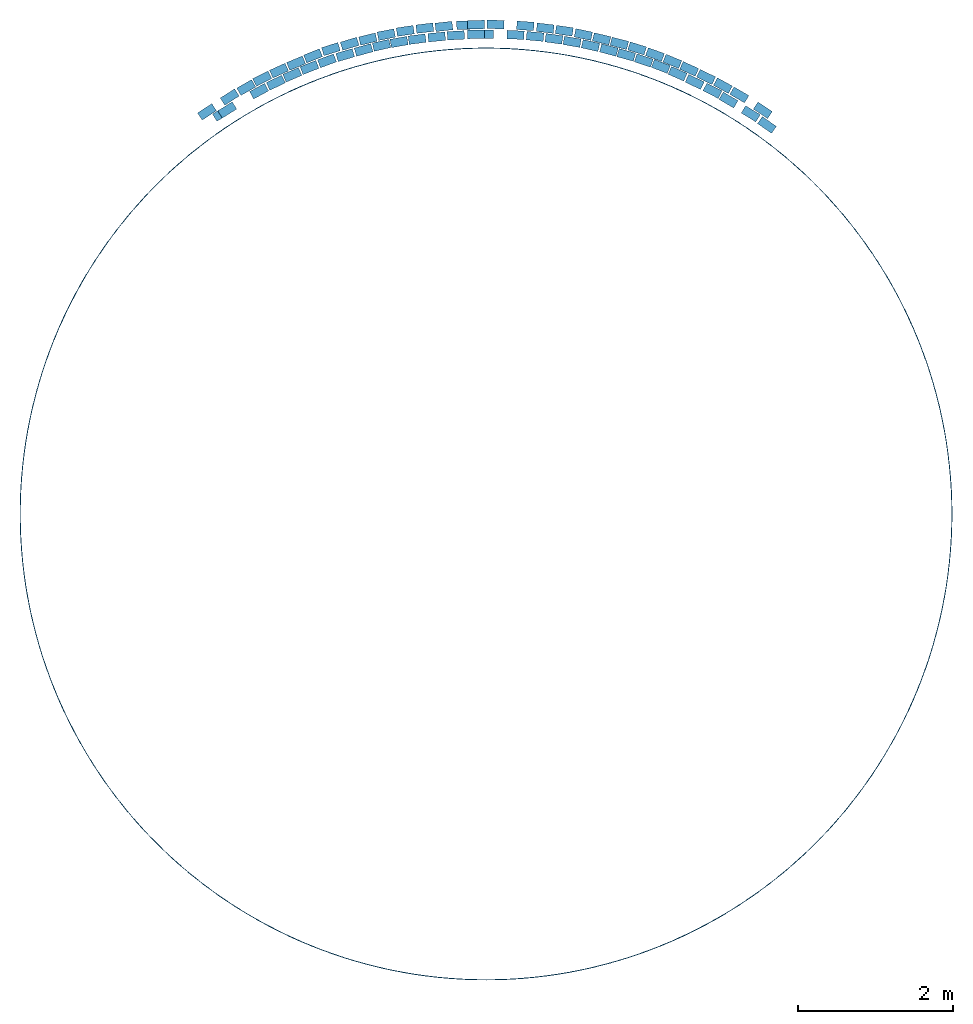
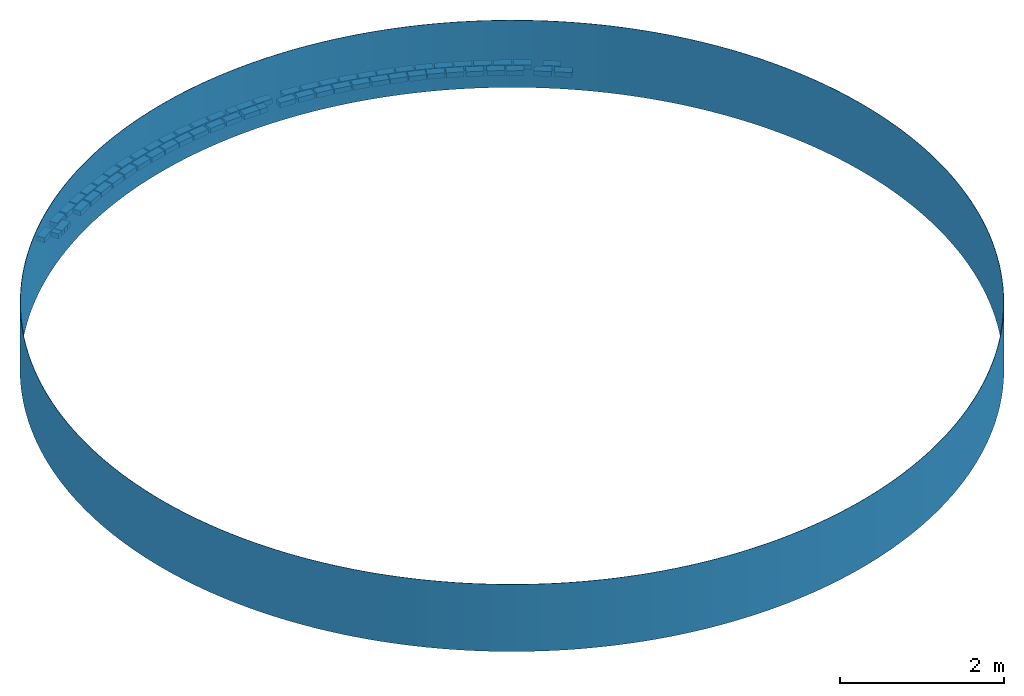
# One storey: 63 assemblies.
"""IFC4 building model written with IfcOpenShell, lengths in millimetres."""

import ifcopenshell
import ifcopenshell.guid

model = None  # the IFC model being written
_history = None  # IfcOwnerHistory: only IFC2X3 demands one
_inside = {}  # id of a spatial element -> (the spatial element, [elements in it])
_under = {}  # id of a project, library or spatial element -> (it, [spatial elements below it])
_declared = {}  # id of a project -> (the project, [libraries it declares])
_typed = {}  # id of a type object -> (the type object, [elements of that type])
_made_of = {}  # id of a material, layer set ... -> (it, [elements and type objects made of it])


def new_model(schema):
    """Start an empty IFC model of exactly this schema.

    Asked for "IFC4X3", IfcOpenShell would pick the latest addendum, in which some entities
    have other attributes; the version numbers below select the first issue.
    IFC2X3 requires an IfcOwnerHistory on every rooted entity: one is made here for all.
    """
    global model, _history
    if schema == "IFC4X3":
        model = ifcopenshell.file(schema_version=(4, 3, 0, 0))
    else:
        model = ifcopenshell.file(schema=schema)
    _inside.clear()
    _under.clear()
    _declared.clear()
    _typed.clear()
    _made_of.clear()
    _history = None
    if model.schema == "IFC2X3":
        org = make("IfcOrganization", Name="unknown")
        user = make(
            "IfcPersonAndOrganization",
            ThePerson=make("IfcPerson", FamilyName="unknown"),
            TheOrganization=org,
        )
        app = make(
            "IfcApplication",
            ApplicationDeveloper=org,
            Version="unknown",
            ApplicationFullName="unknown",
            ApplicationIdentifier="unknown",
        )
        _history = make(
            "IfcOwnerHistory",
            OwningUser=user,
            OwningApplication=app,
            ChangeAction="ADDED",
            CreationDate=0,
        )
    return model


def make(cls, **values):
    """One entity of the class cls with the attributes given. An attribute that is None is left unset."""
    return model.create_entity(
        cls, **{name: value for name, value in values.items() if value is not None}
    )


def entity(cls, *values):
    """Any entity or typed value of the class cls, its attributes in the order of the schema. None: left unset."""
    e = model.create_entity(cls)
    for i, value in enumerate(values):
        if value is not None:
            e[i] = value
    return e


def rooted(cls, **values):
    """An entity with a GlobalId (a new one), such as an element, a storey or a relation."""
    return make(cls, GlobalId=ifcopenshell.guid.new(), OwnerHistory=_history, **values)


def si_unit(unit_type, name, prefix=None):
    """IfcSIUnit, for example si_unit("LENGTHUNIT", "METRE", prefix="MILLI")."""
    return make("IfcSIUnit", UnitType=unit_type, Prefix=prefix, Name=name)


def converted_unit(unit_type, name, factor, base, dimensions=None, offset=None):
    """IfcConversionBasedUnit, such as the inch: factor (a typed value) times the base unit."""
    return make(
        "IfcConversionBasedUnit"
        if offset is None
        else "IfcConversionBasedUnitWithOffset",
        ConversionOffset=offset,
        Dimensions=None
        if dimensions is None
        else entity("IfcDimensionalExponents", *dimensions),
        UnitType=unit_type,
        Name=name,
        ConversionFactor=make(
            "IfcMeasureWithUnit", ValueComponent=factor, UnitComponent=base
        ),
    )


def assignment(units):
    """IfcUnitAssignment: the units of a project."""
    return None if units is None else make("IfcUnitAssignment", Units=units)


def point(xyz):
    """IfcCartesianPoint."""
    return None if xyz is None else make("IfcCartesianPoint", Coordinates=xyz)


def direction(xyz):
    """IfcDirection."""
    return None if xyz is None else make("IfcDirection", DirectionRatios=xyz)


def frame(location, z_axis=None, x_axis=None):
    """IfcAxis2Placement3D, a coordinate frame: its origin and axes. An axis left out is left unset."""
    return make(
        "IfcAxis2Placement3D",
        Location=point(location),
        Axis=direction(z_axis),
        RefDirection=direction(x_axis),
    )


def frame_2d(location, x_axis=None):
    """IfcAxis2Placement2D, a coordinate frame in the plane: its origin and x axis."""
    return make(
        "IfcAxis2Placement2D", Location=point(location), RefDirection=direction(x_axis)
    )


def origin_with_axes():
    """The frame at (0, 0, 0) with the z axis (0, 0, 1) and the x axis (1, 0, 0) written out."""
    return frame((0.0, 0.0, 0.0), z_axis=(0.0, 0.0, 1.0), x_axis=(1.0, 0.0, 0.0))


def origin_2d_with_axis():
    """The frame at (0, 0) in the plane with the x axis (1, 0) written out."""
    return frame_2d((0.0, 0.0), x_axis=(1.0, 0.0))


def place(relative_to, where):
    """IfcLocalPlacement: puts the frame where relative to a parent placement (None: the world)."""
    return make(
        "IfcLocalPlacement", PlacementRelTo=relative_to, RelativePlacement=where
    )


def context(
    kind, dimensions, precision=None, world=None, true_north=None, identifier=None
):
    """IfcGeometricRepresentationContext, for example the 3D "Model" context."""
    return make(
        "IfcGeometricRepresentationContext",
        ContextIdentifier=identifier,
        ContextType=kind,
        CoordinateSpaceDimension=dimensions,
        Precision=precision,
        WorldCoordinateSystem=world,
        TrueNorth=true_north,
    )


def subcontext(parent, identifier, kind, view, scale=None):
    """IfcGeometricRepresentationSubContext, for example "Body" below "Model"."""
    return make(
        "IfcGeometricRepresentationSubContext",
        ContextIdentifier=identifier,
        ContextType=kind,
        ParentContext=parent,
        TargetScale=scale,
        TargetView=view,
    )


def project(units=None, contexts=None):
    """IfcProject with its units and contexts."""
    return rooted(
        "IfcProject",
        Name="project",
        RepresentationContexts=contexts,
        UnitsInContext=assignment(units),
    )


def spatial(cls, under=None, at=None, **own):
    """A site, building, storey or space (cls), placed at a placement, below another one or the project."""
    s = rooted(cls, ObjectPlacement=at, **own)
    if under is not None:
        _under.setdefault(under.id(), (under, []))[1].append(s)
    return s


def profile(cls, at=None, kind="AREA", **sizes):
    """A parametric profile (cls). Its sizes go by their IFC names, for example OverallWidth=200.0."""
    return make(cls, ProfileType=kind, Position=at, **sizes)


def rectangle(**sizes):
    """IfcRectangleProfileDef."""
    return profile("IfcRectangleProfileDef", **sizes)


def hollow_circle(**sizes):
    """IfcCircleHollowProfileDef."""
    return profile("IfcCircleHollowProfileDef", **sizes)


def extrude(swept, where, along, depth):
    """IfcExtrudedAreaSolid: the profile swept, set in the frame where, extruded along a direction by depth."""
    return make(
        "IfcExtrudedAreaSolid",
        SweptArea=swept,
        Position=where,
        ExtrudedDirection=direction(along),
        Depth=depth,
    )


def shape(context_of_items, identifier, shape_type, items):
    """IfcShapeRepresentation: the items that make up one representation, for example the "Body"."""
    return make(
        "IfcShapeRepresentation",
        ContextOfItems=context_of_items,
        RepresentationIdentifier=identifier,
        RepresentationType=shape_type,
        Items=items,
    )


def material(Name=None, Category=None):
    """IfcMaterial."""
    return make("IfcMaterial", Name=Name, Category=Category)


def material_profile(
    of_material, cross_section, Name=None, Category=None, Priority=None
):
    """IfcMaterialProfile: a cross section and its material."""
    return make(
        "IfcMaterialProfile",
        Name=Name,
        Material=of_material,
        Profile=cross_section,
        Priority=Priority,
        Category=Category,
    )


def profile_set(profiles, Name=None, composite=None):
    """IfcMaterialProfileSet."""
    return make(
        "IfcMaterialProfileSet",
        Name=Name,
        MaterialProfiles=profiles,
        CompositeProfile=composite,
    )


def profile_usage(for_profile_set, cardinal=None, extent=None):
    """IfcMaterialProfileSetUsage: how a profile set lies along its element."""
    return make(
        "IfcMaterialProfileSetUsage",
        ForProfileSet=for_profile_set,
        CardinalPoint=cardinal,
        ReferenceExtent=extent,
    )


def made_of(thing, what):
    """Note that an element or type object is made of a material, layer set ...; save() writes the relation."""
    if what is not None:
        _made_of.setdefault(what.id(), (what, []))[1].append(thing)
    return thing


def type_object(cls, material=None, **own):
    """A type object (cls), such as IfcWallType, which elements share."""
    return made_of(rooted(cls, **own), material)


def element(
    cls,
    number,
    at=None,
    inside=None,
    cuts=None,
    type_object=None,
    material=None,
    context=None,
    identifier="Body",
    shape_type=None,
    held_by="IfcProductDefinitionShape",
    body=None,
    shapes=None,
    **own,
):
    """One element of the class cls, such as IfcWall. Its Tag is "e" and its number.

    at: its placement. inside: the storey or other place that contains it. cuts: it is an
    opening in that element (IfcRelVoidsElement). A single representation is given by context,
    identifier, shape_type and body (its items); several are given by shapes. held_by: the class
    of the entity that holds the representations. save() writes the other relations.
    """
    e = rooted(cls, Tag="e%d" % number, ObjectPlacement=at, **own)
    if body is not None:
        shapes = [shape(context, identifier, shape_type, body)]
    if shapes is not None:
        e.Representation = make(held_by, Representations=shapes)
    if inside is not None:
        _inside.setdefault(inside.id(), (inside, []))[1].append(e)
    if cuts is not None:
        rooted(
            "IfcRelVoidsElement", RelatingBuildingElement=cuts, RelatedOpeningElement=e
        )
    if type_object is not None:
        _typed.setdefault(type_object.id(), (type_object, []))[1].append(e)
    return made_of(e, material)


def aggregate(whole, parts):
    """IfcRelAggregates: a whole, such as a stair, and the parts it consists of."""
    return rooted("IfcRelAggregates", RelatingObject=whole, RelatedObjects=parts)


def save(model, path):
    """Write the relations noted so far, then the file.

    IfcRelAggregates (storeys below a building ...), IfcRelContainedInSpatialStructure (elements
    in a storey), IfcRelDefinesByType, IfcRelAssociatesMaterial and IfcRelDeclares: one each for
    every whole, place, type object, material and project.
    """
    for whole, parts in _under.values():
        aggregate(whole, parts)
    for where, things in _inside.values():
        rooted(
            "IfcRelContainedInSpatialStructure",
            RelatedElements=things,
            RelatingStructure=where,
        )
    for kind, things in _typed.values():
        rooted("IfcRelDefinesByType", RelatedObjects=things, RelatingType=kind)
    for what, things in _made_of.values():
        rooted("IfcRelAssociatesMaterial", RelatedObjects=things, RelatingMaterial=what)
    for by, libraries in _declared.values():
        rooted("IfcRelDeclares", RelatingContext=by, RelatedDefinitions=libraries)
    model.write(path)


model = new_model("IFC4")

# Units and contexts
model_context = context("Model", 3, precision=1e-05, world=origin_with_axes())
plan_context = context("Plan", 2, precision=1e-05, world=origin_2d_with_axis())
body_context = subcontext(model_context, "Body", "Model", "MODEL_VIEW")
ifc_project = project(units=[converted_unit("PLANEANGLEUNIT", "degree", entity("IfcReal", 0.0174532925199433), si_unit("PLANEANGLEUNIT", "RADIAN"), dimensions=[0, 0, 0, 0, 0, 0, 0]), si_unit("AREAUNIT", "SQUARE_METRE"), si_unit("VOLUMEUNIT", "CUBIC_METRE"), si_unit("LENGTHUNIT", "METRE", prefix="MILLI")], contexts=[model_context, plan_context])

# Site, building, storey
site_placement = place(None, origin_with_axes())
site = spatial("IfcSite", under=ifc_project, at=site_placement)
building_placement = place(site_placement, origin_with_axes())
building = spatial("IfcBuilding", under=site, at=building_placement, Name="Building")
storey_placement = place(building_placement, origin_with_axes())
storey = spatial("IfcBuildingStorey", under=building, at=storey_placement, Name="Storey")

# Assemblies
ifc_material_1 = material()
ifc_material_profile_1 = material_profile(ifc_material_1, hollow_circle(Radius=6000.0, WallThickness=5.0))
ifc_profile_set_1 = profile_set([ifc_material_profile_1])
ifc_profile_usage_1 = profile_usage(ifc_profile_set_1, cardinal=5)
element_assembly_type_1 = type_object("IfcElementAssemblyType", Name="6m Curve R6m", PredefinedType="ACCESSORY_ASSEMBLY", material=ifc_profile_set_1)
assembly_1_placement = place(storey_placement, frame((0.0, -4800.00019073486, 0.0), z_axis=(0.0, 0.0, 1.0), x_axis=(1.0, 0.0, 0.0)))
element("IfcElementAssembly", 1, at=assembly_1_placement, inside=storey, type_object=element_assembly_type_1, material=ifc_profile_usage_1, Name="ElementAssembly", context=body_context, shape_type="SweptSolid", body=[
    extrude(hollow_circle(Radius=6000.0, WallThickness=5.0), origin_with_axes(), (0.0, 0.0, 1.0), 1000.0),
])
ifc_material_2 = material(Name="NFP-Clay", Category="Bricks")
ifc_material_profile_2 = material_profile(ifc_material_2, rectangle(XDim=220.0, YDim=110.0))
ifc_profile_set_2 = profile_set([ifc_material_profile_2])
ifc_profile_usage_2 = profile_usage(ifc_profile_set_2, cardinal=5)
element_assembly_type_2 = type_object("IfcElementAssemblyType", Name="220x110 brick", PredefinedType="ACCESSORY_ASSEMBLY", material=ifc_profile_set_2)
assembly_2_placement = place(storey_placement, frame((-3331.79354667664, 400.685518980026, 85.9928131103516), z_axis=(0.0, 0.0, 1.0), x_axis=(0.847877833847724, 0.530191643530611, 0.0)))
element("IfcElementAssembly", 2, at=assembly_2_placement, inside=storey, type_object=element_assembly_type_2, material=ifc_profile_usage_2, Name="ElementAssembly", context=body_context, shape_type="SweptSolid", body=[
    extrude(rectangle(XDim=220.0, YDim=110.0), origin_with_axes(), (0.0, 0.0, 1.0), 75.0000014901161),
])
ifc_profile_usage_3 = profile_usage(ifc_profile_set_2, cardinal=5)
assembly_3_placement = place(storey_placement, frame((-3399.42312240601, 358.788222074509, 85.880920290947), z_axis=(0.0, 0.0, 1.0), x_axis=(0.853485229757307, 0.521117033482995, 0.0)))
element("IfcElementAssembly", 3, at=assembly_3_placement, inside=storey, type_object=element_assembly_type_2, material=ifc_profile_usage_3, Name="ElementAssembly", context=body_context, shape_type="SweptSolid", body=[
    extrude(rectangle(XDim=220.0, YDim=110.0), origin_with_axes(), (0.0, 0.0, 1.0), 75.0000014901161),
])
ifc_profile_usage_4 = profile_usage(ifc_profile_set_2, cardinal=5)
assembly_4_placement = place(storey_placement, frame((-2921.75626754761, 642.234444618225, 85.6595560908318), z_axis=(0.0, 0.0, 1.0), x_axis=(0.879846821793852, 0.475257372566967, 0.0)))
element("IfcElementAssembly", 4, at=assembly_4_placement, inside=storey, type_object=element_assembly_type_2, material=ifc_profile_usage_4, Name="ElementAssembly", context=body_context, shape_type="SweptSolid", body=[
    extrude(rectangle(XDim=220.0, YDim=110.0), origin_with_axes(), (0.0, 0.0, 1.0), 74.9999952812988),
])
ifc_profile_usage_5 = profile_usage(ifc_profile_set_2, cardinal=5)
assembly_5_placement = place(storey_placement, frame((-2706.80809020996, 751.53261423111, 85.5487510561943), z_axis=(0.0, 0.0, 1.0), x_axis=(0.90008604523227, 0.435712188466345, 0.0)))
element("IfcElementAssembly", 5, at=assembly_5_placement, inside=storey, type_object=element_assembly_type_2, material=ifc_profile_usage_5, Name="ElementAssembly", context=body_context, shape_type="SweptSolid", body=[
    extrude(rectangle(XDim=220.0, YDim=110.0), origin_with_axes(), (0.0, 0.0, 1.0), 74.9999952812988),
])
ifc_profile_usage_6 = profile_usage(ifc_profile_set_2, cardinal=5)
assembly_6_placement = place(storey_placement, frame((-2494.43316459656, 852.73939371109, 85.3287801146507), z_axis=(0.0, 0.0, 1.0), x_axis=(0.918637789068363, 0.395100762458883, 0.0)))
element("IfcElementAssembly", 6, at=assembly_6_placement, inside=storey, type_object=element_assembly_type_2, material=ifc_profile_usage_6, Name="ElementAssembly", context=body_context, shape_type="SweptSolid", body=[
    extrude(rectangle(XDim=220.0, YDim=110.0), origin_with_axes(), (0.0, 0.0, 1.0), 74.9999952812988),
])
ifc_profile_usage_7 = profile_usage(ifc_profile_set_2, cardinal=5)
assembly_7_placement = place(storey_placement, frame((-2273.21982383728, 947.364151477814, 85.2188915014267), z_axis=(0.0, 0.0, 1.0), x_axis=(0.931043976246126, 0.364906994035198, 0.0)))
element("IfcElementAssembly", 7, at=assembly_7_placement, inside=storey, type_object=element_assembly_type_2, material=ifc_profile_usage_7, Name="ElementAssembly", context=body_context, shape_type="SweptSolid", body=[
    extrude(rectangle(XDim=220.0, YDim=110.0), origin_with_axes(), (0.0, 0.0, 1.0), 75.0000014901161),
])
ifc_profile_usage_8 = profile_usage(ifc_profile_set_2, cardinal=5)
assembly_8_placement = place(storey_placement, frame((-2047.41144180298, 1032.70363807678, 85.2186158299446), z_axis=(0.0, 0.0, 1.0), x_axis=(0.936763820757426, 0.349962203844856, 0.0)))
element("IfcElementAssembly", 8, at=assembly_8_placement, inside=storey, type_object=element_assembly_type_2, material=ifc_profile_usage_8, Name="ElementAssembly", context=body_context, shape_type="SweptSolid", body=[
    extrude(rectangle(XDim=220.0, YDim=110.0), origin_with_axes(), (0.0, 0.0, 1.0), 75.0000108033411),
])
ifc_profile_usage_9 = profile_usage(ifc_profile_set_2, cardinal=5)
assembly_9_placement = place(storey_placement, frame((-1813.19046020508, 1106.92417621613, 85.2183848619461), z_axis=(0.0, 0.0, 1.0), x_axis=(0.96019149097316, 0.279342622352445, 0.0)))
element("IfcElementAssembly", 9, at=assembly_9_placement, inside=storey, type_object=element_assembly_type_2, material=ifc_profile_usage_9, Name="ElementAssembly", context=body_context, shape_type="SweptSolid", body=[
    extrude(rectangle(XDim=220.0, YDim=110.0), origin_with_axes(), (0.0, 0.0, 1.0), 75.0000014901161),
])
ifc_profile_usage_10 = profile_usage(ifc_profile_set_2, cardinal=5)
assembly_10_placement = place(storey_placement, frame((-1345.17168998718, 1233.36791992188, 85.0000008940697), z_axis=(0.0, 0.0, 1.0), x_axis=(0.975997853697929, 0.217780140456003, 0.0)))
element("IfcElementAssembly", 10, at=assembly_10_placement, inside=storey, type_object=element_assembly_type_2, material=ifc_profile_usage_10, Name="ElementAssembly", context=body_context, shape_type="SweptSolid", body=[
    extrude(rectangle(XDim=220.0, YDim=110.0), origin_with_axes(), (0.0, 0.0, 1.0), 74.9999952812988),
])
ifc_profile_usage_11 = profile_usage(ifc_profile_set_2, cardinal=5)
assembly_11_placement = place(storey_placement, frame((-887.34370470047, 1312.5638961792, 85.0000008940697), z_axis=(0.0, 0.0, 1.0), x_axis=(0.991502172084833, 0.13009013318103, 0.0)))
element("IfcElementAssembly", 11, at=assembly_11_placement, inside=storey, type_object=element_assembly_type_2, material=ifc_profile_usage_11, Name="ElementAssembly", context=body_context, shape_type="SweptSolid", body=[
    extrude(rectangle(XDim=220.0, YDim=110.0), origin_with_axes(), (0.0, 0.0, 1.0), 74.9999952812988),
])
ifc_profile_usage_12 = profile_usage(ifc_profile_set_2, cardinal=5)
assembly_12_placement = place(storey_placement, frame((-635.348618030548, 1340.8796787262, 85.0000008940697), z_axis=(0.0, 0.0, 1.0), x_axis=(0.995219850385328, 0.097659865855972, 0.0)))
element("IfcElementAssembly", 12, at=assembly_12_placement, inside=storey, type_object=element_assembly_type_2, material=ifc_profile_usage_12, Name="ElementAssembly", context=body_context, shape_type="SweptSolid", body=[
    extrude(rectangle(XDim=220.0, YDim=110.0), origin_with_axes(), (0.0, 0.0, 1.0), 74.9999952812988),
])
ifc_profile_usage_13 = profile_usage(ifc_profile_set_2, cardinal=5)
assembly_13_placement = place(storey_placement, frame((-1576.66981220245, 1173.41899871826, 85.0000008940697), z_axis=(0.0, 0.0, 1.0), x_axis=(0.963116611925053, 0.269084358211337, 0.0)))
element("IfcElementAssembly", 13, at=assembly_13_placement, inside=storey, type_object=element_assembly_type_2, material=ifc_profile_usage_13, Name="ElementAssembly", context=body_context, shape_type="SweptSolid", body=[
    extrude(rectangle(XDim=220.0, YDim=110.0), origin_with_axes(), (0.0, 0.0, 1.0), 74.9999952812988),
])
ifc_profile_usage_14 = profile_usage(ifc_profile_set_2, cardinal=5)
assembly_14_placement = place(storey_placement, frame((-1119.52376365662, 1275.78008174896, 84.8910510540009), z_axis=(0.0, 0.0, 1.0), x_axis=(0.984706972614554, 0.174218765017663, 0.0)))
element("IfcElementAssembly", 14, at=assembly_14_placement, inside=storey, type_object=element_assembly_type_2, material=ifc_profile_usage_14, Name="ElementAssembly", context=body_context, shape_type="SweptSolid", body=[
    extrude(rectangle(XDim=220.0, YDim=110.0), origin_with_axes(), (0.0, 0.0, 1.0), 75.0000014901161),
])
ifc_profile_usage_15 = profile_usage(ifc_profile_set_2, cardinal=5)
assembly_15_placement = place(storey_placement, frame((-388.857990503311, 1361.08839511871, 85.0000008940697), z_axis=(0.0, 0.0, 1.0), x_axis=(0.998565118226385, 0.0535509538806253, 0.0)))
element("IfcElementAssembly", 15, at=assembly_15_placement, inside=storey, type_object=element_assembly_type_2, material=ifc_profile_usage_15, Name="ElementAssembly", context=body_context, shape_type="SweptSolid", body=[
    extrude(rectangle(XDim=220.0, YDim=110.0), origin_with_axes(), (0.0, 0.0, 1.0), 74.9999952812988),
])
ifc_profile_usage_16 = profile_usage(ifc_profile_set_2, cardinal=5)
assembly_16_placement = place(storey_placement, frame((-127.596870064735, 1374.1660118103, 85.0000008940697), z_axis=(0.0, 0.0, 1.0), x_axis=(0.999856891366211, 0.0169173516691517, 0.0)))
element("IfcElementAssembly", 16, at=assembly_16_placement, inside=storey, type_object=element_assembly_type_2, material=ifc_profile_usage_16, Name="ElementAssembly", context=body_context, shape_type="SweptSolid", body=[
    extrude(rectangle(XDim=220.0, YDim=110.0), origin_with_axes(), (0.0, 0.0, 1.0), 74.9999952812988),
])
ifc_profile_usage_17 = profile_usage(ifc_profile_set_2, cardinal=5)
assembly_17_placement = place(storey_placement, frame((379.935592412949, 1367.30241775513, 85.0000008940697), z_axis=(0.0, 0.0, 1.0), x_axis=(0.998911995512758, -0.0466350213972176, 0.0)))
element("IfcElementAssembly", 17, at=assembly_17_placement, inside=storey, type_object=element_assembly_type_2, material=ifc_profile_usage_17, Name="ElementAssembly", context=body_context, shape_type="SweptSolid", body=[
    extrude(rectangle(XDim=220.0, YDim=110.0), origin_with_axes(), (0.0, 0.0, 1.0), 74.9999952812988),
])
ifc_profile_usage_18 = profile_usage(ifc_profile_set_2, cardinal=5)
assembly_18_placement = place(storey_placement, frame((874.041378498077, 1316.41280651093, 85.0000008940697), z_axis=(0.0, 0.0, 1.0), x_axis=(0.990802661700397, -0.135314764779786, 0.0)))
element("IfcElementAssembly", 18, at=assembly_18_placement, inside=storey, type_object=element_assembly_type_2, material=ifc_profile_usage_18, Name="ElementAssembly", context=body_context, shape_type="SweptSolid", body=[
    extrude(rectangle(XDim=220.0, YDim=110.0), origin_with_axes(), (0.0, 0.0, 1.0), 74.9999952812988),
])
ifc_profile_usage_19 = profile_usage(ifc_profile_set_2, cardinal=5)
assembly_19_placement = place(storey_placement, frame((1108.33239555359, 1278.09202671051, 85.0000008940697), z_axis=(0.0, 0.0, 1.0), x_axis=(0.985858309690939, -0.167581004929929, 0.0)))
element("IfcElementAssembly", 19, at=assembly_19_placement, inside=storey, type_object=element_assembly_type_2, material=ifc_profile_usage_19, Name="ElementAssembly", context=body_context, shape_type="SweptSolid", body=[
    extrude(rectangle(XDim=220.0, YDim=110.0), origin_with_axes(), (0.0, 0.0, 1.0), 74.9999952812988),
])
ifc_profile_usage_20 = profile_usage(ifc_profile_set_2, cardinal=5)
assembly_20_placement = place(storey_placement, frame((1344.73240375519, 1230.12733459473, 85.0000008940697), z_axis=(0.0, 0.0, 1.0), x_axis=(0.975237523052608, -0.221160063370886, 0.0)))
element("IfcElementAssembly", 20, at=assembly_20_placement, inside=storey, type_object=element_assembly_type_2, material=ifc_profile_usage_20, Name="ElementAssembly", context=body_context, shape_type="SweptSolid", body=[
    extrude(rectangle(XDim=220.0, YDim=110.0), origin_with_axes(), (0.0, 0.0, 1.0), 74.9999952812988),
])
ifc_profile_usage_21 = profile_usage(ifc_profile_set_2, cardinal=5)
assembly_21_placement = place(storey_placement, frame((2030.36856651306, 1036.75627708435, 85.0000008940697), z_axis=(0.0, 0.0, 1.0), x_axis=(0.948487526914305, -0.316814474555669, 0.0)))
element("IfcElementAssembly", 21, at=assembly_21_placement, inside=storey, type_object=element_assembly_type_2, material=ifc_profile_usage_21, Name="ElementAssembly", context=body_context, shape_type="SweptSolid", body=[
    extrude(rectangle(XDim=220.0, YDim=110.0), origin_with_axes(), (0.0, 0.0, 1.0), 74.9999952812988),
])
ifc_profile_usage_22 = profile_usage(ifc_profile_set_2, cardinal=5)
assembly_22_placement = place(storey_placement, frame((1805.14693260193, 1109.64739322662, 85.0000604987144), z_axis=(0.0, 0.0, 1.0), x_axis=(0.963913118564089, -0.266217016473502, 0.0)))
element("IfcElementAssembly", 22, at=assembly_22_placement, inside=storey, type_object=element_assembly_type_2, material=ifc_profile_usage_22, Name="ElementAssembly", context=body_context, shape_type="SweptSolid", body=[
    extrude(rectangle(XDim=220.0, YDim=110.0), origin_with_axes(), (0.0, 0.0, 1.0), 74.9999952812988),
])
ifc_profile_usage_23 = profile_usage(ifc_profile_set_2, cardinal=5)
assembly_23_placement = place(storey_placement, frame((-16.2874758243561, 1376.40273571014, 85.0000008940697), z_axis=(0.0, 0.0, 1.0), x_axis=(0.999980463063441, 0.00625087925225182, 0.0)))
element("IfcElementAssembly", 23, at=assembly_23_placement, inside=storey, type_object=element_assembly_type_2, material=ifc_profile_usage_23, Name="ElementAssembly", context=body_context, shape_type="SweptSolid", body=[
    extrude(rectangle(XDim=220.0, YDim=110.0), origin_with_axes(), (0.0, 0.0, 1.0), 74.9999952812988),
])
ifc_profile_usage_24 = profile_usage(ifc_profile_set_2, cardinal=5)
assembly_24_placement = place(storey_placement, frame((630.780816078186, 1347.8639125824, 85.0000008940697), z_axis=(0.0, 0.0, 1.0), x_axis=(0.995855168341088, -0.0909531950419712, 0.0)))
element("IfcElementAssembly", 24, at=assembly_24_placement, inside=storey, type_object=element_assembly_type_2, material=ifc_profile_usage_24, Name="ElementAssembly", context=body_context, shape_type="SweptSolid", body=[
    extrude(rectangle(XDim=220.0, YDim=110.0), origin_with_axes(), (0.0, 0.0, 1.0), 74.9999952812988),
])
ifc_profile_usage_25 = profile_usage(ifc_profile_set_2, cardinal=5)
assembly_25_placement = place(storey_placement, frame((1581.51066303253, 1172.3119020462, 85.0000008940697), z_axis=(0.0, 0.0, 1.0), x_axis=(0.966698037772156, -0.255919721333592, 0.0)))
element("IfcElementAssembly", 25, at=assembly_25_placement, inside=storey, type_object=element_assembly_type_2, material=ifc_profile_usage_25, Name="ElementAssembly", context=body_context, shape_type="SweptSolid", body=[
    extrude(rectangle(XDim=220.0, YDim=110.0), origin_with_axes(), (0.0, 0.0, 1.0), 74.9999952812988),
])
ifc_profile_usage_26 = profile_usage(ifc_profile_set_2, cardinal=5)
assembly_26_placement = place(storey_placement, frame((2465.95144271851, 866.807579994202, 85.0000008940697), z_axis=(0.0, 0.0, 1.0), x_axis=(0.916542121386628, -0.399938169876419, 0.0)))
element("IfcElementAssembly", 26, at=assembly_26_placement, inside=storey, type_object=element_assembly_type_2, material=ifc_profile_usage_26, Name="ElementAssembly", context=body_context, shape_type="SweptSolid", body=[
    extrude(rectangle(XDim=220.0, YDim=110.0), origin_with_axes(), (0.0, 0.0, 1.0), 74.9999952812988),
])
ifc_profile_usage_27 = profile_usage(ifc_profile_set_2, cardinal=5)
assembly_27_placement = place(storey_placement, frame((2685.6803894043, 761.28089427948, 85.0000008940697), z_axis=(0.0, 0.0, 1.0), x_axis=(0.903000853407706, -0.429638753774557, 0.0)))
element("IfcElementAssembly", 27, at=assembly_27_placement, inside=storey, type_object=element_assembly_type_2, material=ifc_profile_usage_27, Name="ElementAssembly", context=body_context, shape_type="SweptSolid", body=[
    extrude(rectangle(XDim=220.0, YDim=110.0), origin_with_axes(), (0.0, 0.0, 1.0), 74.9999952812988),
])
ifc_profile_usage_28 = profile_usage(ifc_profile_set_2, cardinal=5)
assembly_28_placement = place(storey_placement, frame((2249.68957901001, 961.217939853668, 85.0000008940697), z_axis=(0.0, 0.0, 1.0), x_axis=(0.933481087233346, -0.358626630045302, 0.0)))
element("IfcElementAssembly", 28, at=assembly_28_placement, inside=storey, type_object=element_assembly_type_2, material=ifc_profile_usage_28, Name="ElementAssembly", context=body_context, shape_type="SweptSolid", body=[
    extrude(rectangle(XDim=220.0, YDim=110.0), origin_with_axes(), (0.0, 0.0, 1.0), 74.9999952812988),
])
ifc_profile_usage_29 = profile_usage(ifc_profile_set_2, cardinal=5)
assembly_29_placement = place(storey_placement, frame((2915.60196876526, 647.53395318985, 85.0000008940697), z_axis=(0.0, 0.0, 1.0), x_axis=(0.890690683087444, -0.454609840479968, 0.0)))
element("IfcElementAssembly", 29, at=assembly_29_placement, inside=storey, type_object=element_assembly_type_2, material=ifc_profile_usage_29, Name="ElementAssembly", context=body_context, shape_type="SweptSolid", body=[
    extrude(rectangle(XDim=220.0, YDim=110.0), origin_with_axes(), (0.0, 0.0, 1.0), 74.9999952812988),
])
ifc_profile_usage_30 = profile_usage(ifc_profile_set_2, cardinal=5)
assembly_30_placement = place(storey_placement, frame((3616.15562438965, 207.670345902443, 85.0000604987144), z_axis=(0.0, 0.0, 1.0), x_axis=(0.821770464597586, -0.56981865844764, 0.0)))
element("IfcElementAssembly", 30, at=assembly_30_placement, inside=storey, type_object=element_assembly_type_2, material=ifc_profile_usage_30, Name="ElementAssembly", context=body_context, shape_type="SweptSolid", body=[
    extrude(rectangle(XDim=220.0, YDim=110.0), origin_with_axes(), (0.0, 0.0, 1.0), 74.9999952812988),
])
ifc_profile_usage_31 = profile_usage(ifc_profile_set_2, cardinal=5)
assembly_31_placement = place(storey_placement, frame((3407.7033996582, 351.046711206436, 85.0000008940697), z_axis=(0.0, 0.0, 1.0), x_axis=(0.854896744377706, -0.518798184704225, 0.0)))
element("IfcElementAssembly", 31, at=assembly_31_placement, inside=storey, type_object=element_assembly_type_2, material=ifc_profile_usage_31, Name="ElementAssembly", context=body_context, shape_type="SweptSolid", body=[
    extrude(rectangle(XDim=220.0, YDim=110.0), origin_with_axes(), (0.0, 0.0, 1.0), 74.9999952812988),
])
ifc_profile_usage_32 = profile_usage(ifc_profile_set_2, cardinal=5)
assembly_32_placement = place(storey_placement, frame((3121.25253677368, 528.716027736664, 85.0000008940697), z_axis=(0.0, 0.0, 1.0), x_axis=(0.86696965204166, -0.498360935907665, 0.0)))
element("IfcElementAssembly", 32, at=assembly_32_placement, inside=storey, type_object=element_assembly_type_2, material=ifc_profile_usage_32, Name="ElementAssembly", context=body_context, shape_type="SweptSolid", body=[
    extrude(rectangle(XDim=220.0, YDim=110.0), origin_with_axes(), (0.0, 0.0, 1.0), 74.9999952812988),
])
ifc_profile_usage_33 = profile_usage(ifc_profile_set_2, cardinal=5)
assembly_33_placement = place(storey_placement, frame((-1755.80060482025, 1252.97105312347, 85.0000008940697), z_axis=(0.0, 0.0, 1.0), x_axis=(0.957384254989481, 0.288817222994469, 0.0)))
element("IfcElementAssembly", 33, at=assembly_33_placement, inside=storey, type_object=element_assembly_type_2, material=ifc_profile_usage_33, Name="ElementAssembly", context=body_context, shape_type="SweptSolid", body=[
    extrude(rectangle(XDim=220.0, YDim=110.0), origin_with_axes(), (0.0, 0.0, 1.0), 74.9999952812988),
])
ifc_profile_usage_34 = profile_usage(ifc_profile_set_2, cardinal=5)
assembly_34_placement = place(storey_placement, frame((-541.972696781158, 1476.19736194611, 85.0000008940697), z_axis=(0.0, 0.0, 1.0), x_axis=(0.993747006614565, 0.11165521413974, 0.0)))
element("IfcElementAssembly", 34, at=assembly_34_placement, inside=storey, type_object=element_assembly_type_2, material=ifc_profile_usage_34, Name="ElementAssembly", context=body_context, shape_type="SweptSolid", body=[
    extrude(rectangle(XDim=220.0, YDim=110.0), origin_with_axes(), (0.0, 0.0, 1.0), 74.9999952812988),
])
ifc_profile_usage_35 = profile_usage(ifc_profile_set_2, cardinal=5)
assembly_35_placement = place(storey_placement, frame((-3300.18663406372, 567.3708319664, 85.0000008940697), z_axis=(0.0, 0.0, 1.0), x_axis=(0.842597355515596, 0.53854405249536, 0.0)))
element("IfcElementAssembly", 35, at=assembly_35_placement, inside=storey, type_object=element_assembly_type_2, material=ifc_profile_usage_35, Name="ElementAssembly", context=body_context, shape_type="SweptSolid", body=[
    extrude(rectangle(XDim=220.0, YDim=110.0), origin_with_axes(), (0.0, 0.0, 1.0), 74.9999952812988),
])
ifc_profile_usage_36 = profile_usage(ifc_profile_set_2, cardinal=5)
assembly_36_placement = place(storey_placement, frame((-2881.34121894836, 803.790807723999, 85.0000008940697), z_axis=(0.0, 0.0, 1.0), x_axis=(0.890943179287464, 0.454114799672006, 0.0)))
element("IfcElementAssembly", 36, at=assembly_36_placement, inside=storey, type_object=element_assembly_type_2, material=ifc_profile_usage_36, Name="ElementAssembly", context=body_context, shape_type="SweptSolid", body=[
    extrude(rectangle(XDim=220.0, YDim=110.0), origin_with_axes(), (0.0, 0.0, 1.0), 74.9999952812988),
])
ifc_profile_usage_37 = profile_usage(ifc_profile_set_2, cardinal=5)
assembly_37_placement = place(storey_placement, frame((1007.02834129333, 1420.79055309296, 85.0000008940697), z_axis=(0.0, 0.0, 1.0), x_axis=(0.98909355557912, -0.147288622479316, 0.0)))
element("IfcElementAssembly", 37, at=assembly_37_placement, inside=storey, type_object=element_assembly_type_2, material=ifc_profile_usage_37, Name="ElementAssembly", context=body_context, shape_type="SweptSolid", body=[
    extrude(rectangle(XDim=220.0, YDim=110.0), origin_with_axes(), (0.0, 0.0, 1.0), 74.9999952812988),
])
ifc_profile_usage_38 = profile_usage(ifc_profile_set_2, cardinal=5)
assembly_38_placement = place(storey_placement, frame((1487.88034915924, 1316.35558605194, 85.0000008940697), z_axis=(0.0, 0.0, 1.0), x_axis=(0.971752471651742, -0.236002402188473, 0.0)))
element("IfcElementAssembly", 38, at=assembly_38_placement, inside=storey, type_object=element_assembly_type_2, material=ifc_profile_usage_38, Name="ElementAssembly", context=body_context, shape_type="SweptSolid", body=[
    extrude(rectangle(XDim=220.0, YDim=110.0), origin_with_axes(), (0.0, 0.0, 1.0), 74.9999952812988),
])
ifc_profile_usage_39 = profile_usage(ifc_profile_set_2, cardinal=5)
assembly_39_placement = place(storey_placement, frame((505.744576454163, 1483.46960544586, 85.0000008940697), z_axis=(0.0, 0.0, 1.0), x_axis=(0.99751378768454, -0.0704715785210053, 0.0)))
element("IfcElementAssembly", 39, at=assembly_39_placement, inside=storey, type_object=element_assembly_type_2, material=ifc_profile_usage_39, Name="ElementAssembly", context=body_context, shape_type="SweptSolid", body=[
    extrude(rectangle(XDim=220.0, YDim=110.0), origin_with_axes(), (0.0, 0.0, 1.0), 74.9999952812988),
])
ifc_profile_usage_40 = profile_usage(ifc_profile_set_2, cardinal=5)
assembly_40_placement = place(storey_placement, frame((-2445.48320770264, 1003.33142280579, 85.0000008940697), z_axis=(0.0, 0.0, 1.0), x_axis=(0.923349429868638, 0.383960714606665, 0.0)))
element("IfcElementAssembly", 40, at=assembly_40_placement, inside=storey, type_object=element_assembly_type_2, material=ifc_profile_usage_40, Name="ElementAssembly", context=body_context, shape_type="SweptSolid", body=[
    extrude(rectangle(XDim=220.0, YDim=110.0), origin_with_axes(), (0.0, 0.0, 1.0), 74.9999952812988),
])
ifc_profile_usage_41 = profile_usage(ifc_profile_set_2, cardinal=5)
assembly_41_placement = place(storey_placement, frame((-1997.37286567688, 1183.93051624298, 85.0000008940697), z_axis=(0.0, 0.0, 1.0), x_axis=(0.954248957785271, 0.299013254832833, 0.0)))
element("IfcElementAssembly", 41, at=assembly_41_placement, inside=storey, type_object=element_assembly_type_2, material=ifc_profile_usage_41, Name="ElementAssembly", context=body_context, shape_type="SweptSolid", body=[
    extrude(rectangle(XDim=220.0, YDim=110.0), origin_with_axes(), (0.0, 0.0, 1.0), 74.9999952812988),
])
ifc_profile_usage_42 = profile_usage(ifc_profile_set_2, cardinal=5)
assembly_42_placement = place(storey_placement, frame((-1039.66617584229, 1418.67828369141, 85.0000008940697), z_axis=(0.0, 0.0, 1.0), x_axis=(0.98861980446993, 0.150435641421297, 0.0)))
element("IfcElementAssembly", 42, at=assembly_42_placement, inside=storey, type_object=element_assembly_type_2, material=ifc_profile_usage_42, Name="ElementAssembly", context=body_context, shape_type="SweptSolid", body=[
    extrude(rectangle(XDim=220.0, YDim=110.0), origin_with_axes(), (0.0, 0.0, 1.0), 74.9999952812988),
])
ifc_profile_usage_43 = profile_usage(ifc_profile_set_2, cardinal=5)
assembly_43_placement = place(storey_placement, frame((123.001724481583, 1501.31130218506, 85.0000008940697), z_axis=(0.0, 0.0, 1.0), x_axis=(0.999659338389456, -0.0260999457998595, 0.0)))
element("IfcElementAssembly", 43, at=assembly_43_placement, inside=storey, type_object=element_assembly_type_2, material=ifc_profile_usage_43, Name="ElementAssembly", context=body_context, shape_type="SweptSolid", body=[
    extrude(rectangle(XDim=220.0, YDim=110.0), origin_with_axes(), (0.0, 0.0, 1.0), 74.9999952812988),
])
ifc_profile_usage_44 = profile_usage(ifc_profile_set_2, cardinal=5)
assembly_44_placement = place(storey_placement, frame((1715.55685997009, 1258.29946994781, 85.0000604987144), z_axis=(0.0, 0.0, 1.0), x_axis=(0.969179730449814, -0.246354724097643, 0.0)))
element("IfcElementAssembly", 44, at=assembly_44_placement, inside=storey, type_object=element_assembly_type_2, material=ifc_profile_usage_44, Name="ElementAssembly", context=body_context, shape_type="SweptSolid", body=[
    extrude(rectangle(XDim=220.0, YDim=110.0), origin_with_axes(), (0.0, 0.0, 1.0), 74.9999952812988),
])
ifc_profile_usage_45 = profile_usage(ifc_profile_set_2, cardinal=5)
assembly_45_placement = place(storey_placement, frame((-3592.30470657349, 376.804530620575, 85.0000008940697), z_axis=(0.0, 0.0, 1.0), x_axis=(0.83680466771328, 0.547501550767911, 0.0)))
element("IfcElementAssembly", 45, at=assembly_45_placement, inside=storey, type_object=element_assembly_type_2, material=ifc_profile_usage_45, Name="ElementAssembly", context=body_context, shape_type="SweptSolid", body=[
    extrude(rectangle(XDim=220.0, YDim=110.0), origin_with_axes(), (0.0, 0.0, 1.0), 74.9999952812988),
])
ifc_profile_usage_46 = profile_usage(ifc_profile_set_2, cardinal=5)
assembly_46_placement = place(storey_placement, frame((-1521.09456062317, 1313.43448162079, 85.0000008940697), z_axis=(0.0, 0.0, 1.0), x_axis=(0.971316938019612, 0.237788573981606, 0.0)))
element("IfcElementAssembly", 46, at=assembly_46_placement, inside=storey, type_object=element_assembly_type_2, material=ifc_profile_usage_46, Name="ElementAssembly", context=body_context, shape_type="SweptSolid", body=[
    extrude(rectangle(XDim=220.0, YDim=110.0), origin_with_axes(), (0.0, 0.0, 1.0), 74.9999952812988),
])
ifc_profile_usage_47 = profile_usage(ifc_profile_set_2, cardinal=5)
assembly_47_placement = place(storey_placement, frame((762.167036533356, 1454.2236328125, 85.0000008940697), z_axis=(0.0, 0.0, 1.0), x_axis=(0.993373870890346, -0.114927597348635, 0.0)))
element("IfcElementAssembly", 47, at=assembly_47_placement, inside=storey, type_object=element_assembly_type_2, material=ifc_profile_usage_47, Name="ElementAssembly", context=body_context, shape_type="SweptSolid", body=[
    extrude(rectangle(XDim=220.0, YDim=110.0), origin_with_axes(), (0.0, 0.0, 1.0), 74.9999952812988),
])
ifc_profile_usage_48 = profile_usage(ifc_profile_set_2, cardinal=5)
assembly_48_placement = place(storey_placement, frame((-3086.80629730225, 689.511299133301, 85.0000008940697), z_axis=(0.0, 0.0, 1.0), x_axis=(0.869895689954459, 0.493235733294595, 0.0)))
element("IfcElementAssembly", 48, at=assembly_48_placement, inside=storey, type_object=element_assembly_type_2, material=ifc_profile_usage_48, Name="ElementAssembly", context=body_context, shape_type="SweptSolid", body=[
    extrude(rectangle(XDim=220.0, YDim=110.0), origin_with_axes(), (0.0, 0.0, 1.0), 74.9999952812988),
])
ifc_profile_usage_49 = profile_usage(ifc_profile_set_2, cardinal=5)
assembly_49_placement = place(storey_placement, frame((-268.10485124588, 1492.91384220123, 85.0000008940697), z_axis=(0.0, 0.0, 1.0), x_axis=(0.999298187021941, 0.0374584224796281, 0.0)))
element("IfcElementAssembly", 49, at=assembly_49_placement, inside=storey, type_object=element_assembly_type_2, material=ifc_profile_usage_49, Name="ElementAssembly", context=body_context, shape_type="SweptSolid", body=[
    extrude(rectangle(XDim=220.0, YDim=110.0), origin_with_axes(), (0.0, 0.0, 1.0), 74.9999952812988),
])
ifc_profile_usage_50 = profile_usage(ifc_profile_set_2, cardinal=5)
assembly_50_placement = place(storey_placement, frame((-127.959489822388, 1499.103307724, 85.0000008940697), z_axis=(0.0, 0.0, 1.0), x_axis=(0.999640902791731, 0.0267967435658167, 0.0)))
element("IfcElementAssembly", 50, at=assembly_50_placement, inside=storey, type_object=element_assembly_type_2, material=ifc_profile_usage_50, Name="ElementAssembly", context=body_context, shape_type="SweptSolid", body=[
    extrude(rectangle(XDim=220.0, YDim=110.0), origin_with_axes(), (0.0, 0.0, 1.0), 74.9999952812988),
])
ifc_profile_usage_51 = profile_usage(ifc_profile_set_2, cardinal=5)
assembly_51_placement = place(storey_placement, frame((2174.25537109375, 1113.43574523926, 85.0000008940697), z_axis=(0.0, 0.0, 1.0), x_axis=(0.940652917524658, -0.339370135327712, 0.0)))
element("IfcElementAssembly", 51, at=assembly_51_placement, inside=storey, type_object=element_assembly_type_2, material=ifc_profile_usage_51, Name="ElementAssembly", context=body_context, shape_type="SweptSolid", body=[
    extrude(rectangle(XDim=220.0, YDim=110.0), origin_with_axes(), (0.0, 0.0, 1.0), 74.9999952812988),
])
ifc_profile_usage_52 = profile_usage(ifc_profile_set_2, cardinal=5)
assembly_52_placement = place(storey_placement, frame((-2226.84144973755, 1097.46360778809, 85.0000008940697), z_axis=(0.0, 0.0, 1.0), x_axis=(0.929375163109731, 0.369136568487545, 0.0)))
element("IfcElementAssembly", 52, at=assembly_52_placement, inside=storey, type_object=element_assembly_type_2, material=ifc_profile_usage_52, Name="ElementAssembly", context=body_context, shape_type="SweptSolid", body=[
    extrude(rectangle(XDim=220.0, YDim=110.0), origin_with_axes(), (0.0, 0.0, 1.0), 74.9999952812988),
])
ifc_profile_usage_53 = profile_usage(ifc_profile_set_2, cardinal=5)
assembly_53_placement = place(storey_placement, frame((-788.393318653107, 1454.15091514587, 85.0000008940697), z_axis=(0.0, 0.0, 1.0), x_axis=(0.993003060714462, 0.11808861677448, 0.0)))
element("IfcElementAssembly", 53, at=assembly_53_placement, inside=storey, type_object=element_assembly_type_2, material=ifc_profile_usage_53, Name="ElementAssembly", context=body_context, shape_type="SweptSolid", body=[
    extrude(rectangle(XDim=220.0, YDim=110.0), origin_with_axes(), (0.0, 0.0, 1.0), 74.9999952812988),
])
ifc_profile_usage_54 = profile_usage(ifc_profile_set_2, cardinal=5)
assembly_54_placement = place(storey_placement, frame((2398.01120758057, 1026.28886699677, 85.0000008940697), z_axis=(0.0, 0.0, 1.0), x_axis=(0.924566397166969, -0.381020966916114, 0.0)))
element("IfcElementAssembly", 54, at=assembly_54_placement, inside=storey, type_object=element_assembly_type_2, material=ifc_profile_usage_54, Name="ElementAssembly", context=body_context, shape_type="SweptSolid", body=[
    extrude(rectangle(XDim=220.0, YDim=110.0), origin_with_axes(), (0.0, 0.0, 1.0), 74.9999952812988),
])
ifc_profile_usage_55 = profile_usage(ifc_profile_set_2, cardinal=5)
assembly_55_placement = place(storey_placement, frame((2832.73243904114, 825.454771518707, 85.0000008940697), z_axis=(0.0, 0.0, 1.0), x_axis=(0.899843762970542, -0.436212336188485, 0.0)))
element("IfcElementAssembly", 55, at=assembly_55_placement, inside=storey, type_object=element_assembly_type_2, material=ifc_profile_usage_55, Name="ElementAssembly", context=body_context, shape_type="SweptSolid", body=[
    extrude(rectangle(XDim=220.0, YDim=110.0), origin_with_axes(), (0.0, 0.0, 1.0), 74.9999952812988),
])
ifc_profile_usage_56 = profile_usage(ifc_profile_set_2, cardinal=5)
assembly_56_placement = place(storey_placement, frame((3562.91627883911, 396.649122238159, 85.0000604987144), z_axis=(0.0, 0.0, 1.0), x_axis=(0.833305347653343, -0.552812986074261, 0.0)))
element("IfcElementAssembly", 56, at=assembly_56_placement, inside=storey, type_object=element_assembly_type_2, material=ifc_profile_usage_56, Name="ElementAssembly", context=body_context, shape_type="SweptSolid", body=[
    extrude(rectangle(XDim=220.0, YDim=110.0), origin_with_axes(), (0.0, 0.0, 1.0), 74.9999952812988),
])
ifc_profile_usage_57 = profile_usage(ifc_profile_set_2, cardinal=5)
assembly_57_placement = place(storey_placement, frame((3049.41391944885, 713.961064815521, 85.0000008940697), z_axis=(0.0, 0.0, 1.0), x_axis=(0.877026736997066, -0.480441570424833, 0.0)))
element("IfcElementAssembly", 57, at=assembly_57_placement, inside=storey, type_object=element_assembly_type_2, material=ifc_profile_usage_57, Name="ElementAssembly", context=body_context, shape_type="SweptSolid", body=[
    extrude(rectangle(XDim=220.0, YDim=110.0), origin_with_axes(), (0.0, 0.0, 1.0), 74.9999952812988),
])
ifc_profile_usage_58 = profile_usage(ifc_profile_set_2, cardinal=5)
assembly_58_placement = place(storey_placement, frame((-2665.6506061554, 907.59801864624, 85.0000008940697), z_axis=(0.0, 0.0, 1.0), x_axis=(0.910325464180178, 0.41389316165545, 0.0)))
element("IfcElementAssembly", 58, at=assembly_58_placement, inside=storey, type_object=element_assembly_type_2, material=ifc_profile_usage_58, Name="ElementAssembly", context=body_context, shape_type="SweptSolid", body=[
    extrude(rectangle(XDim=220.0, YDim=110.0), origin_with_axes(), (0.0, 0.0, 1.0), 74.9999952812988),
])
ifc_profile_usage_59 = profile_usage(ifc_profile_set_2, cardinal=5)
assembly_59_placement = place(storey_placement, frame((-1284.35385227203, 1371.13153934479, 85.0000008940697), z_axis=(0.0, 0.0, 1.0), x_axis=(0.980919303590468, 0.194415328211516, 0.0)))
element("IfcElementAssembly", 59, at=assembly_59_placement, inside=storey, type_object=element_assembly_type_2, material=ifc_profile_usage_59, Name="ElementAssembly", context=body_context, shape_type="SweptSolid", body=[
    extrude(rectangle(XDim=220.0, YDim=110.0), origin_with_axes(), (0.0, 0.0, 1.0), 74.9999952812988),
])
ifc_profile_usage_60 = profile_usage(ifc_profile_set_2, cardinal=5)
assembly_60_placement = place(storey_placement, frame((1252.76386737823, 1372.09343910217, 85.0000008940697), z_axis=(0.0, 0.0, 1.0), x_axis=(0.979575934246872, -0.201074585774456, 0.0)))
element("IfcElementAssembly", 60, at=assembly_60_placement, inside=storey, type_object=element_assembly_type_2, material=ifc_profile_usage_60, Name="ElementAssembly", context=body_context, shape_type="SweptSolid", body=[
    extrude(rectangle(XDim=220.0, YDim=110.0), origin_with_axes(), (0.0, 0.0, 1.0), 74.9999952812988),
])
ifc_profile_usage_61 = profile_usage(ifc_profile_set_2, cardinal=5)
assembly_61_placement = place(storey_placement, frame((1945.02830505371, 1192.85142421722, 85.0000008940697), z_axis=(0.0, 0.0, 1.0), x_axis=(0.954797050146253, -0.29725846166596, 0.0)))
element("IfcElementAssembly", 61, at=assembly_61_placement, inside=storey, type_object=element_assembly_type_2, material=ifc_profile_usage_61, Name="ElementAssembly", context=body_context, shape_type="SweptSolid", body=[
    extrude(rectangle(XDim=220.0, YDim=110.0), origin_with_axes(), (0.0, 0.0, 1.0), 74.9999952812988),
])
ifc_profile_usage_62 = profile_usage(ifc_profile_set_2, cardinal=5)
assembly_62_placement = place(storey_placement, frame((3260.46705245972, 594.581127166748, 85.0000008940697), z_axis=(0.0, 0.0, 1.0), x_axis=(0.865376300701612, -0.501122597957818, 0.0)))
element("IfcElementAssembly", 62, at=assembly_62_placement, inside=storey, type_object=element_assembly_type_2, material=ifc_profile_usage_62, Name="ElementAssembly", context=body_context, shape_type="SweptSolid", body=[
    extrude(rectangle(XDim=220.0, YDim=110.0), origin_with_axes(), (0.0, 0.0, 1.0), 74.9999952812988),
])
ifc_profile_usage_63 = profile_usage(ifc_profile_set_2, cardinal=5)
assembly_63_placement = place(storey_placement, frame((2615.2024269104, 929.89307641983, 85.0000008940697), z_axis=(0.0, 0.0, 1.0), x_axis=(0.911638243275244, -0.410993568560419, 0.0)))
element("IfcElementAssembly", 63, at=assembly_63_placement, inside=storey, type_object=element_assembly_type_2, material=ifc_profile_usage_63, Name="ElementAssembly", context=body_context, shape_type="SweptSolid", body=[
    extrude(rectangle(XDim=220.0, YDim=110.0), origin_with_axes(), (0.0, 0.0, 1.0), 74.9999952812988),
])

save(model, "model.ifc")
